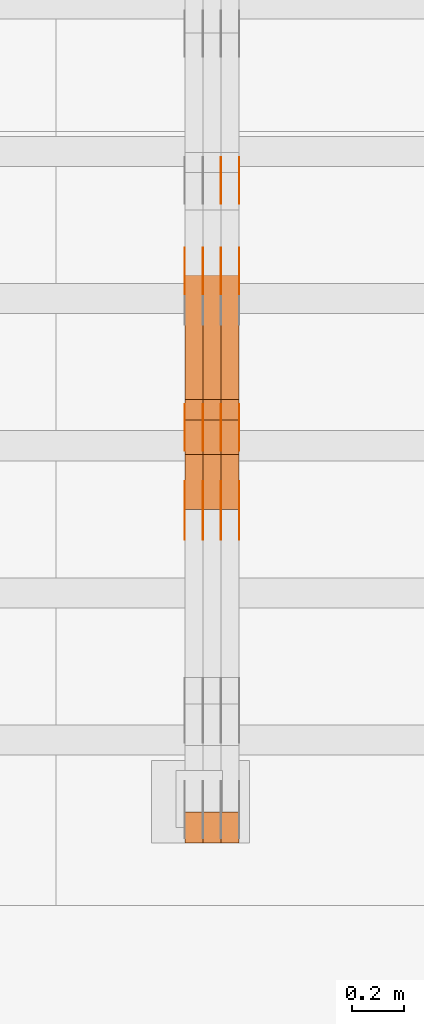
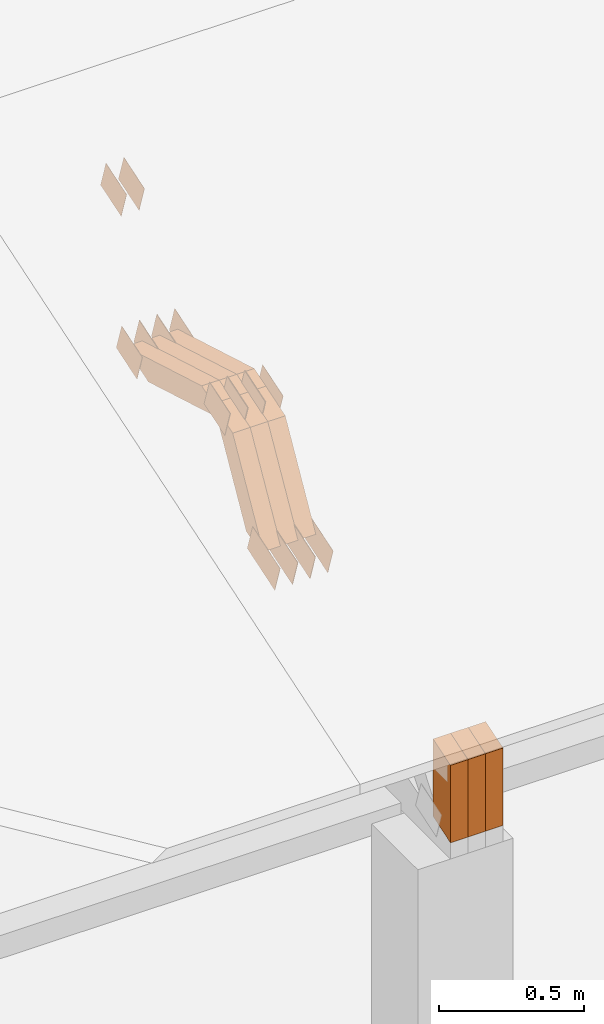
# One storey, part 129 of 385: 29 proxies.
"""IFC2X3 building model written with IfcOpenShell, lengths in millimetres."""

from ifc_helpers import new_model, entity, si_unit, converted_unit, derived_unit, direction, frame, origin, place, context, subcontext, project, spatial, polyline, outline, extrude, source, transform, mapped, material, type_object, type_shapes, element, save


model = new_model("IFC2X3")

# Units and contexts
model_context = context("Model", 3, precision=0.01, world=origin(), true_north=direction((6.12303176911189e-17, 1.0)))
body_context = subcontext(model_context, "Body", "Model", "MODEL_VIEW")
ifc_project = project(units=[si_unit("LENGTHUNIT", "METRE", prefix="MILLI"), si_unit("AREAUNIT", "SQUARE_METRE"), si_unit("VOLUMEUNIT", "CUBIC_METRE"), converted_unit("PLANEANGLEUNIT", "DEGREE", entity("IfcRatioMeasure", 0.0174532925199433), si_unit("PLANEANGLEUNIT", "RADIAN"), dimensions=[0, 0, 0, 0, 0, 0, 0]), si_unit("MASSUNIT", "GRAM", prefix="KILO"), derived_unit("MASSDENSITYUNIT", [(si_unit("MASSUNIT", "GRAM", prefix="KILO"), 1), (si_unit("LENGTHUNIT", "METRE"), -3)]), si_unit("TIMEUNIT", "SECOND"), si_unit("FREQUENCYUNIT", "HERTZ"), si_unit("THERMODYNAMICTEMPERATUREUNIT", "DEGREE_CELSIUS"), derived_unit("THERMALTRANSMITTANCEUNIT", [(si_unit("MASSUNIT", "GRAM", prefix="KILO"), 1), (si_unit("THERMODYNAMICTEMPERATUREUNIT", "KELVIN"), -1), (si_unit("TIMEUNIT", "SECOND"), -3)]), derived_unit("VOLUMETRICFLOWRATEUNIT", [(si_unit("LENGTHUNIT", "METRE"), 3), (si_unit("TIMEUNIT", "SECOND"), -1)]), si_unit("ELECTRICCURRENTUNIT", "AMPERE"), si_unit("ELECTRICVOLTAGEUNIT", "VOLT"), si_unit("POWERUNIT", "WATT"), si_unit("FORCEUNIT", "NEWTON", prefix="KILO"), si_unit("ILLUMINANCEUNIT", "LUX"), si_unit("LUMINOUSFLUXUNIT", "LUMEN"), si_unit("LUMINOUSINTENSITYUNIT", "CANDELA"), derived_unit("USERDEFINED", [(si_unit("MASSUNIT", "GRAM", prefix="KILO"), -1), (si_unit("LENGTHUNIT", "METRE"), -2), (si_unit("TIMEUNIT", "SECOND"), 3), (si_unit("LUMINOUSFLUXUNIT", "LUMEN"), 1)]), derived_unit("LINEARVELOCITYUNIT", [(si_unit("LENGTHUNIT", "METRE"), 1), (si_unit("TIMEUNIT", "SECOND"), -1)]), si_unit("PRESSUREUNIT", "PASCAL"), derived_unit("USERDEFINED", [(si_unit("LENGTHUNIT", "METRE"), -2), (si_unit("MASSUNIT", "GRAM", prefix="KILO"), 1), (si_unit("TIMEUNIT", "SECOND"), -2)])], contexts=[model_context])

# Site, building, storey
site_placement = place(None, origin())
site = spatial("IfcSite", under=ifc_project, at=site_placement, CompositionType="ELEMENT")
building_placement = place(site_placement, origin())
building = spatial("IfcBuilding", under=site, at=building_placement, CompositionType="ELEMENT")
storey_placement = place(building_placement, origin())
storey = spatial("IfcBuildingStorey", under=building, at=storey_placement, Name="Default", CompositionType="ELEMENT", Elevation=0.0)

# Proxies
ifc_material_1 = material(Name="IfcSurfaceStyle #374118")
building_element_proxy_type_1 = type_object("IfcBuildingElementProxyType", PredefinedType="NOTDEFINED", material=ifc_material_1)
shared_shape_1 = source(origin(), body_context, "Body", "SweptSolid", [
    extrude(outline(polyline([(-99.9998204243802, -60.000067376167), (99.9998338462265, -60.000067376167), (99.9998204243802, 60.000067376167), (-99.9998338462265, 60.000067376167), (-99.9998204243802, -60.000067376167)])), frame((100.000602015329, 60.0001864986889, 0.0), z_axis=(0.0, 0.0, 1.0), x_axis=(-1.0, 0.0, 0.0)), (0.0, 0.0, 1.0), 1.3),
])
type_shapes(building_element_proxy_type_1, [shared_shape_1])
proxy_1_placement = place(building_placement, frame((30386.3, 4114.85465165112, 513.097031388771), z_axis=(-1.0, 0.0, 0.0), x_axis=(0.0, 0.951056516295124, 0.309016994375039)))
element("IfcBuildingElementProxy", 1, at=proxy_1_placement, inside=storey, type_object=building_element_proxy_type_1, material=ifc_material_1, context=body_context, shape_type="MappedRepresentation", body=[
    mapped(shared_shape_1, transform((0.0, 0.0, 0.0), scale=1.0)),
])
ifc_material_2 = material(Name="IfcSurfaceStyle #374061")
building_element_proxy_type_2 = type_object("IfcBuildingElementProxyType", PredefinedType="NOTDEFINED", material=ifc_material_2)
shared_shape_2 = source(origin(), body_context, "Body", "SweptSolid", [
    extrude(outline(polyline([(-99.9998204243802, -60.000067376167), (99.9998338462265, -60.000067376167), (99.9998204243802, 60.000067376167), (-99.9998338462265, 60.000067376167), (-99.9998204243802, -60.000067376167)])), frame((100.000602015329, 60.0001864986889, 0.0), z_axis=(0.0, 0.0, 1.0), x_axis=(-1.0, 0.0, 0.0)), (0.0, 0.0, 1.0), 1.3),
])
type_shapes(building_element_proxy_type_2, [shared_shape_2])
proxy_2_placement = place(building_placement, frame((30315.0, 4114.85465165112, 513.097031388771), z_axis=(-1.0, 0.0, 0.0), x_axis=(0.0, 0.951056516295124, 0.309016994375039)))
element("IfcBuildingElementProxy", 2, at=proxy_2_placement, inside=storey, type_object=building_element_proxy_type_2, material=ifc_material_2, context=body_context, shape_type="MappedRepresentation", body=[
    mapped(shared_shape_2, transform((0.0, 0.0, 0.0), scale=1.0)),
])
ifc_material_3 = material(Name="IfcSurfaceStyle #374004")
building_element_proxy_type_3 = type_object("IfcBuildingElementProxyType", PredefinedType="NOTDEFINED", material=ifc_material_3)
shared_shape_3 = source(origin(), body_context, "Body", "SweptSolid", [
    extrude(outline(polyline([(-99.9998204243802, -60.000067376167), (99.9998338462265, -60.000067376167), (99.9998204243802, 60.000067376167), (-99.9998338462265, 60.000067376167), (-99.9998204243802, -60.000067376167)])), frame((100.000602015329, 60.0001864986889, 0.0), z_axis=(0.0, 0.0, 1.0), x_axis=(-1.0, 0.0, 0.0)), (0.0, 0.0, 1.0), 1.3),
])
type_shapes(building_element_proxy_type_3, [shared_shape_3])
proxy_3_placement = place(building_placement, frame((30316.3, 4114.85465165112, 513.097031388771), z_axis=(-1.0, 0.0, 0.0), x_axis=(0.0, 0.951056516295124, 0.309016994375039)))
element("IfcBuildingElementProxy", 3, at=proxy_3_placement, inside=storey, type_object=building_element_proxy_type_3, material=ifc_material_3, context=body_context, shape_type="MappedRepresentation", body=[
    mapped(shared_shape_3, transform((0.0, 0.0, 0.0), scale=1.0)),
])
ifc_material_4 = material(Name="IfcSurfaceStyle #373947")
building_element_proxy_type_4 = type_object("IfcBuildingElementProxyType", PredefinedType="NOTDEFINED", material=ifc_material_4)
shared_shape_4 = source(origin(), body_context, "Body", "SweptSolid", [
    extrude(outline(polyline([(-99.9998204243802, -60.000067376167), (99.9998338462265, -60.000067376167), (99.9998204243802, 60.000067376167), (-99.9998338462265, 60.000067376167), (-99.9998204243802, -60.000067376167)])), frame((100.000602015329, 60.0001864986889, 0.0), z_axis=(0.0, 0.0, 1.0), x_axis=(-1.0, 0.0, 0.0)), (0.0, 0.0, 1.0), 1.29999999999998),
])
type_shapes(building_element_proxy_type_4, [shared_shape_4])
proxy_4_placement = place(building_placement, frame((30245.0, 4114.85465165112, 513.097031388771), z_axis=(-1.0, 0.0, 0.0), x_axis=(0.0, 0.951056516295124, 0.309016994375039)))
element("IfcBuildingElementProxy", 4, at=proxy_4_placement, inside=storey, type_object=building_element_proxy_type_4, material=ifc_material_4, context=body_context, shape_type="MappedRepresentation", body=[
    mapped(shared_shape_4, transform((0.0, 0.0, 0.0), scale=1.0)),
])
ifc_material_5 = material(Name="IfcSurfaceStyle #373890")
building_element_proxy_type_5 = type_object("IfcBuildingElementProxyType", PredefinedType="NOTDEFINED", material=ifc_material_5)
shared_shape_5 = source(origin(), body_context, "Body", "SweptSolid", [
    extrude(outline(polyline([(-99.9998204243802, -60.000067376167), (99.9998338462265, -60.000067376167), (99.9998204243802, 60.000067376167), (-99.9998338462265, 60.000067376167), (-99.9998204243802, -60.000067376167)])), frame((100.000602015329, 60.0001864986889, 0.0), z_axis=(0.0, 0.0, 1.0), x_axis=(-1.0, 0.0, 0.0)), (0.0, 0.0, 1.0), 1.29999999999998),
])
type_shapes(building_element_proxy_type_5, [shared_shape_5])
proxy_5_placement = place(building_placement, frame((30246.3, 4114.85465165112, 513.097031388771), z_axis=(-1.0, 0.0, 0.0), x_axis=(0.0, 0.951056516295124, 0.309016994375039)))
element("IfcBuildingElementProxy", 5, at=proxy_5_placement, inside=storey, type_object=building_element_proxy_type_5, material=ifc_material_5, context=body_context, shape_type="MappedRepresentation", body=[
    mapped(shared_shape_5, transform((0.0, 0.0, 0.0), scale=1.0)),
])
ifc_material_6 = material(Name="IfcSurfaceStyle #373833")
building_element_proxy_type_6 = type_object("IfcBuildingElementProxyType", PredefinedType="NOTDEFINED", material=ifc_material_6)
shared_shape_6 = source(origin(), body_context, "Body", "SweptSolid", [
    extrude(outline(polyline([(-99.9998204243802, -60.000067376167), (99.9998338462265, -60.000067376167), (99.9998204243802, 60.000067376167), (-99.9998338462265, 60.000067376167), (-99.9998204243802, -60.000067376167)])), frame((100.000602015329, 60.0001864986889, 0.0), z_axis=(0.0, 0.0, 1.0), x_axis=(-1.0, 0.0, 0.0)), (0.0, 0.0, 1.0), 1.29999999999999),
])
type_shapes(building_element_proxy_type_6, [shared_shape_6])
proxy_6_placement = place(building_placement, frame((30175.0, 4114.85465165112, 513.097031388771), z_axis=(-1.0, 0.0, 0.0), x_axis=(0.0, 0.951056516295124, 0.309016994375039)))
element("IfcBuildingElementProxy", 6, at=proxy_6_placement, inside=storey, type_object=building_element_proxy_type_6, material=ifc_material_6, context=body_context, shape_type="MappedRepresentation", body=[
    mapped(shared_shape_6, transform((0.0, 0.0, 0.0), scale=1.0)),
])
ifc_material_7 = material(Name="IfcSurfaceStyle #373776")
building_element_proxy_type_7 = type_object("IfcBuildingElementProxyType", PredefinedType="NOTDEFINED", material=ifc_material_7)
shared_shape_7 = source(origin(), body_context, "Body", "SweptSolid", [
    extrude(outline(polyline([(-74.9998707133927, -60.0000596852269), (74.9998841352353, -60.0000596852269), (74.999861282944, 60.0000596852269), (-74.9998747047866, 60.0000596852269), (-74.9998707133927, -60.0000596852269)])), frame((74.9998841352353, 60.0000596852269, 0.0), z_axis=(0.0, 0.0, 1.0), x_axis=(-1.0, 0.0, 0.0)), (0.0, 0.0, 1.0), 1.3),
])
type_shapes(building_element_proxy_type_7, [shared_shape_7])
proxy_7_placement = place(building_placement, frame((30386.3, 5067.4882362875, 826.131473120182), z_axis=(-1.0, 0.0, 0.0), x_axis=(0.0, 0.951056516295124, 0.309016994375039)))
element("IfcBuildingElementProxy", 7, at=proxy_7_placement, inside=storey, type_object=building_element_proxy_type_7, material=ifc_material_7, context=body_context, shape_type="MappedRepresentation", body=[
    mapped(shared_shape_7, transform((0.0, 0.0, 0.0), scale=1.0)),
])
ifc_material_8 = material(Name="IfcSurfaceStyle #373719")
building_element_proxy_type_8 = type_object("IfcBuildingElementProxyType", PredefinedType="NOTDEFINED", material=ifc_material_8)
shared_shape_8 = source(origin(), body_context, "Body", "SweptSolid", [
    extrude(outline(polyline([(-74.9998707133927, -60.0000596852269), (74.9998841352353, -60.0000596852269), (74.999861282944, 60.0000596852269), (-74.9998747047866, 60.0000596852269), (-74.9998707133927, -60.0000596852269)])), frame((74.9998841352353, 60.0000596852269, 0.0), z_axis=(0.0, 0.0, 1.0), x_axis=(-1.0, 0.0, 0.0)), (0.0, 0.0, 1.0), 1.3),
])
type_shapes(building_element_proxy_type_8, [shared_shape_8])
proxy_8_placement = place(building_placement, frame((30315.0, 5067.4882362875, 826.131473120182), z_axis=(-1.0, 0.0, 0.0), x_axis=(0.0, 0.951056516295124, 0.309016994375039)))
element("IfcBuildingElementProxy", 8, at=proxy_8_placement, inside=storey, type_object=building_element_proxy_type_8, material=ifc_material_8, context=body_context, shape_type="MappedRepresentation", body=[
    mapped(shared_shape_8, transform((0.0, 0.0, 0.0), scale=1.0)),
])
ifc_material_9 = material(Name="IfcSurfaceStyle #373662")
building_element_proxy_type_9 = type_object("IfcBuildingElementProxyType", PredefinedType="NOTDEFINED", material=ifc_material_9)
shared_shape_9 = source(origin(), body_context, "Body", "SweptSolid", [
    extrude(outline(polyline([(-74.9998707133927, -60.0000596852269), (74.9998841352353, -60.0000596852269), (74.999861282944, 60.0000596852269), (-74.9998747047866, 60.0000596852269), (-74.9998707133927, -60.0000596852269)])), frame((74.9998841352353, 60.0000596852269, 0.0), z_axis=(0.0, 0.0, 1.0), x_axis=(-1.0, 0.0, 0.0)), (0.0, 0.0, 1.0), 1.3),
])
type_shapes(building_element_proxy_type_9, [shared_shape_9])
proxy_9_placement = place(building_placement, frame((30316.3, 5067.4882362875, 826.131473120182), z_axis=(-1.0, 0.0, 0.0), x_axis=(0.0, 0.951056516295124, 0.309016994375039)))
element("IfcBuildingElementProxy", 9, at=proxy_9_placement, inside=storey, type_object=building_element_proxy_type_9, material=ifc_material_9, context=body_context, shape_type="MappedRepresentation", body=[
    mapped(shared_shape_9, transform((0.0, 0.0, 0.0), scale=1.0)),
])
ifc_material_10 = material(Name="IfcSurfaceStyle #373605")
building_element_proxy_type_10 = type_object("IfcBuildingElementProxyType", PredefinedType="NOTDEFINED", material=ifc_material_10)
shared_shape_10 = source(origin(), body_context, "Body", "SweptSolid", [
    extrude(outline(polyline([(-74.9998707133927, -60.0000596852269), (74.9998841352353, -60.0000596852269), (74.999861282944, 60.0000596852269), (-74.9998747047866, 60.0000596852269), (-74.9998707133927, -60.0000596852269)])), frame((74.9998841352353, 60.0000596852269, 0.0), z_axis=(0.0, 0.0, 1.0), x_axis=(-1.0, 0.0, 0.0)), (0.0, 0.0, 1.0), 1.29999999999999),
])
type_shapes(building_element_proxy_type_10, [shared_shape_10])
proxy_10_placement = place(building_placement, frame((30245.0, 5067.4882362875, 826.131473120182), z_axis=(-1.0, 0.0, 0.0), x_axis=(0.0, 0.951056516295124, 0.309016994375039)))
element("IfcBuildingElementProxy", 10, at=proxy_10_placement, inside=storey, type_object=building_element_proxy_type_10, material=ifc_material_10, context=body_context, shape_type="MappedRepresentation", body=[
    mapped(shared_shape_10, transform((0.0, 0.0, 0.0), scale=1.0)),
])
ifc_material_11 = material(Name="IfcSurfaceStyle #373548")
building_element_proxy_type_11 = type_object("IfcBuildingElementProxyType", PredefinedType="NOTDEFINED", material=ifc_material_11)
shared_shape_11 = source(origin(), body_context, "Body", "SweptSolid", [
    extrude(outline(polyline([(-74.9998707133927, -60.0000596852269), (74.9998841352353, -60.0000596852269), (74.999861282944, 60.0000596852269), (-74.9998747047866, 60.0000596852269), (-74.9998707133927, -60.0000596852269)])), frame((74.9998841352353, 60.0000596852269, 0.0), z_axis=(0.0, 0.0, 1.0), x_axis=(-1.0, 0.0, 0.0)), (0.0, 0.0, 1.0), 1.29999999999999),
])
type_shapes(building_element_proxy_type_11, [shared_shape_11])
proxy_11_placement = place(building_placement, frame((30246.3, 5067.4882362875, 826.131473120182), z_axis=(-1.0, 0.0, 0.0), x_axis=(0.0, 0.951056516295124, 0.309016994375039)))
element("IfcBuildingElementProxy", 11, at=proxy_11_placement, inside=storey, type_object=building_element_proxy_type_11, material=ifc_material_11, context=body_context, shape_type="MappedRepresentation", body=[
    mapped(shared_shape_11, transform((0.0, 0.0, 0.0), scale=1.0)),
])
ifc_material_12 = material(Name="IfcSurfaceStyle #373491")
building_element_proxy_type_12 = type_object("IfcBuildingElementProxyType", PredefinedType="NOTDEFINED", material=ifc_material_12)
shared_shape_12 = source(origin(), body_context, "Body", "SweptSolid", [
    extrude(outline(polyline([(-74.9998707133927, -60.0000596852269), (74.9998841352353, -60.0000596852269), (74.999861282944, 60.0000596852269), (-74.9998747047866, 60.0000596852269), (-74.9998707133927, -60.0000596852269)])), frame((74.9998841352353, 60.0000596852269, 0.0), z_axis=(0.0, 0.0, 1.0), x_axis=(-1.0, 0.0, 0.0)), (0.0, 0.0, 1.0), 1.29999999999999),
])
type_shapes(building_element_proxy_type_12, [shared_shape_12])
proxy_12_placement = place(building_placement, frame((30175.0, 5067.4882362875, 826.131473120182), z_axis=(-1.0, 0.0, 0.0), x_axis=(0.0, 0.951056516295124, 0.309016994375039)))
element("IfcBuildingElementProxy", 12, at=proxy_12_placement, inside=storey, type_object=building_element_proxy_type_12, material=ifc_material_12, context=body_context, shape_type="MappedRepresentation", body=[
    mapped(shared_shape_12, transform((0.0, 0.0, 0.0), scale=1.0)),
])
ifc_material_13 = material(Name="IfcSurfaceStyle #367962")
building_element_proxy_type_13 = type_object("IfcBuildingElementProxyType", PredefinedType="NOTDEFINED", material=ifc_material_13)
shared_shape_13 = source(origin(), body_context, "Body", "SweptSolid", [
    extrude(outline(polyline([(-74.9998565677224, -60.0000596852342), (74.9998794200083, -60.0000596852342), (74.9998565677242, 60.0000596852342), (-74.9998794200101, 60.0000596852342), (-74.9998565677224, -60.0000596852342)])), frame((74.9998794200083, 60.0000596852342, 0.0), z_axis=(0.0, 0.0, 1.0), x_axis=(-1.0, 0.0, 0.0)), (0.0, 0.0, 1.0), 1.3),
])
type_shapes(building_element_proxy_type_13, [shared_shape_13])
proxy_13_placement = place(building_placement, frame((30386.3, 5418.6991737875, 1250.81341892098), z_axis=(-1.0, 0.0, 0.0), x_axis=(0.0, 0.951056516295154, 0.309016994374948)))
element("IfcBuildingElementProxy", 13, at=proxy_13_placement, inside=storey, type_object=building_element_proxy_type_13, material=ifc_material_13, context=body_context, shape_type="MappedRepresentation", body=[
    mapped(shared_shape_13, transform((0.0, 0.0, 0.0), scale=1.0)),
])
ifc_material_14 = material(Name="IfcSurfaceStyle #367905")
building_element_proxy_type_14 = type_object("IfcBuildingElementProxyType", PredefinedType="NOTDEFINED", material=ifc_material_14)
shared_shape_14 = source(origin(), body_context, "Body", "SweptSolid", [
    extrude(outline(polyline([(-74.9998565677224, -60.0000596852342), (74.9998794200083, -60.0000596852342), (74.9998565677242, 60.0000596852342), (-74.9998794200101, 60.0000596852342), (-74.9998565677224, -60.0000596852342)])), frame((74.9998794200083, 60.0000596852342, 0.0), z_axis=(0.0, 0.0, 1.0), x_axis=(-1.0, 0.0, 0.0)), (0.0, 0.0, 1.0), 1.3),
])
type_shapes(building_element_proxy_type_14, [shared_shape_14])
proxy_14_placement = place(building_placement, frame((30315.0, 5418.6991737875, 1250.81341892098), z_axis=(-1.0, 0.0, 0.0), x_axis=(0.0, 0.951056516295154, 0.309016994374948)))
element("IfcBuildingElementProxy", 14, at=proxy_14_placement, inside=storey, type_object=building_element_proxy_type_14, material=ifc_material_14, context=body_context, shape_type="MappedRepresentation", body=[
    mapped(shared_shape_14, transform((0.0, 0.0, 0.0), scale=1.0)),
])
ifc_material_15 = material(Name="IfcSurfaceStyle #366936")
building_element_proxy_type_15 = type_object("IfcBuildingElementProxyType", PredefinedType="NOTDEFINED", material=ifc_material_15)
shared_shape_15 = source(origin(), body_context, "Body", "SweptSolid", [
    extrude(outline(polyline([(-74.999865998172, -60.0000306612919), (74.999869989555, -60.0000306612919), (74.999865998172, 60.0000306612919), (-74.999869989555, 60.0000306612919), (-74.999865998172, -60.0000306612919)])), frame((75.0006726017528, 60.0001996460842, 0.0), z_axis=(0.0, 0.0, 1.0), x_axis=(-1.0, 0.0, 0.0)), (0.0, 0.0, 1.0), 1.3),
])
type_shapes(building_element_proxy_type_15, [shared_shape_15])
proxy_15_placement = place(building_placement, frame((30386.3, 4460.38978242656, 957.314497110567), z_axis=(-1.0, 0.0, 0.0), x_axis=(0.0, 0.951056516295154, 0.309016994374948)))
element("IfcBuildingElementProxy", 15, at=proxy_15_placement, inside=storey, type_object=building_element_proxy_type_15, material=ifc_material_15, context=body_context, shape_type="MappedRepresentation", body=[
    mapped(shared_shape_15, transform((0.0, 0.0, 0.0), scale=1.0)),
])
ifc_material_16 = material(Name="IfcSurfaceStyle #366879")
building_element_proxy_type_16 = type_object("IfcBuildingElementProxyType", PredefinedType="NOTDEFINED", material=ifc_material_16)
shared_shape_16 = source(origin(), body_context, "Body", "SweptSolid", [
    extrude(outline(polyline([(-74.999865998172, -60.0000306612919), (74.999869989555, -60.0000306612919), (74.999865998172, 60.0000306612919), (-74.999869989555, 60.0000306612919), (-74.999865998172, -60.0000306612919)])), frame((75.0006726017528, 60.0001996460842, 0.0), z_axis=(0.0, 0.0, 1.0), x_axis=(-1.0, 0.0, 0.0)), (0.0, 0.0, 1.0), 1.3),
])
type_shapes(building_element_proxy_type_16, [shared_shape_16])
proxy_16_placement = place(building_placement, frame((30315.0, 4460.38978242656, 957.314497110567), z_axis=(-1.0, 0.0, 0.0), x_axis=(0.0, 0.951056516295154, 0.309016994374948)))
element("IfcBuildingElementProxy", 16, at=proxy_16_placement, inside=storey, type_object=building_element_proxy_type_16, material=ifc_material_16, context=body_context, shape_type="MappedRepresentation", body=[
    mapped(shared_shape_16, transform((0.0, 0.0, 0.0), scale=1.0)),
])
ifc_material_17 = material(Name="IfcSurfaceStyle #366822")
building_element_proxy_type_17 = type_object("IfcBuildingElementProxyType", PredefinedType="NOTDEFINED", material=ifc_material_17)
shared_shape_17 = source(origin(), body_context, "Body", "SweptSolid", [
    extrude(outline(polyline([(-74.999865998172, -60.0000306612919), (74.999869989555, -60.0000306612919), (74.999865998172, 60.0000306612919), (-74.999869989555, 60.0000306612919), (-74.999865998172, -60.0000306612919)])), frame((75.0006726017528, 60.0001996460842, 0.0), z_axis=(0.0, 0.0, 1.0), x_axis=(-1.0, 0.0, 0.0)), (0.0, 0.0, 1.0), 1.3),
])
type_shapes(building_element_proxy_type_17, [shared_shape_17])
proxy_17_placement = place(building_placement, frame((30316.3, 4460.38978242656, 957.314497110567), z_axis=(-1.0, 0.0, 0.0), x_axis=(0.0, 0.951056516295154, 0.309016994374948)))
element("IfcBuildingElementProxy", 17, at=proxy_17_placement, inside=storey, type_object=building_element_proxy_type_17, material=ifc_material_17, context=body_context, shape_type="MappedRepresentation", body=[
    mapped(shared_shape_17, transform((0.0, 0.0, 0.0), scale=1.0)),
])
ifc_material_18 = material(Name="IfcSurfaceStyle #366765")
building_element_proxy_type_18 = type_object("IfcBuildingElementProxyType", PredefinedType="NOTDEFINED", material=ifc_material_18)
shared_shape_18 = source(origin(), body_context, "Body", "SweptSolid", [
    extrude(outline(polyline([(-74.999865998172, -60.0000306612919), (74.999869989555, -60.0000306612919), (74.999865998172, 60.0000306612919), (-74.999869989555, 60.0000306612919), (-74.999865998172, -60.0000306612919)])), frame((75.0006726017528, 60.0001996460842, 0.0), z_axis=(0.0, 0.0, 1.0), x_axis=(-1.0, 0.0, 0.0)), (0.0, 0.0, 1.0), 1.29999999999999),
])
type_shapes(building_element_proxy_type_18, [shared_shape_18])
proxy_18_placement = place(building_placement, frame((30245.0, 4460.38978242656, 957.314497110567), z_axis=(-1.0, 0.0, 0.0), x_axis=(0.0, 0.951056516295154, 0.309016994374948)))
element("IfcBuildingElementProxy", 18, at=proxy_18_placement, inside=storey, type_object=building_element_proxy_type_18, material=ifc_material_18, context=body_context, shape_type="MappedRepresentation", body=[
    mapped(shared_shape_18, transform((0.0, 0.0, 0.0), scale=1.0)),
])
ifc_material_19 = material(Name="IfcSurfaceStyle #366708")
building_element_proxy_type_19 = type_object("IfcBuildingElementProxyType", PredefinedType="NOTDEFINED", material=ifc_material_19)
shared_shape_19 = source(origin(), body_context, "Body", "SweptSolid", [
    extrude(outline(polyline([(-74.999865998172, -60.0000306612919), (74.999869989555, -60.0000306612919), (74.999865998172, 60.0000306612919), (-74.999869989555, 60.0000306612919), (-74.999865998172, -60.0000306612919)])), frame((75.0006726017528, 60.0001996460842, 0.0), z_axis=(0.0, 0.0, 1.0), x_axis=(-1.0, 0.0, 0.0)), (0.0, 0.0, 1.0), 1.29999999999999),
])
type_shapes(building_element_proxy_type_19, [shared_shape_19])
proxy_19_placement = place(building_placement, frame((30246.3, 4460.38978242656, 957.314497110567), z_axis=(-1.0, 0.0, 0.0), x_axis=(0.0, 0.951056516295154, 0.309016994374948)))
element("IfcBuildingElementProxy", 19, at=proxy_19_placement, inside=storey, type_object=building_element_proxy_type_19, material=ifc_material_19, context=body_context, shape_type="MappedRepresentation", body=[
    mapped(shared_shape_19, transform((0.0, 0.0, 0.0), scale=1.0)),
])
ifc_material_20 = material(Name="IfcSurfaceStyle #366651")
building_element_proxy_type_20 = type_object("IfcBuildingElementProxyType", PredefinedType="NOTDEFINED", material=ifc_material_20)
shared_shape_20 = source(origin(), body_context, "Body", "SweptSolid", [
    extrude(outline(polyline([(-74.999865998172, -60.0000306612919), (74.999869989555, -60.0000306612919), (74.999865998172, 60.0000306612919), (-74.999869989555, 60.0000306612919), (-74.999865998172, -60.0000306612919)])), frame((75.0006726017528, 60.0001996460842, 0.0), z_axis=(0.0, 0.0, 1.0), x_axis=(-1.0, 0.0, 0.0)), (0.0, 0.0, 1.0), 1.29999999999999),
])
type_shapes(building_element_proxy_type_20, [shared_shape_20])
proxy_20_placement = place(building_placement, frame((30175.0, 4460.38978242656, 957.314497110567), z_axis=(-1.0, 0.0, 0.0), x_axis=(0.0, 0.951056516295154, 0.309016994374948)))
element("IfcBuildingElementProxy", 20, at=proxy_20_placement, inside=storey, type_object=building_element_proxy_type_20, material=ifc_material_20, context=body_context, shape_type="MappedRepresentation", body=[
    mapped(shared_shape_20, transform((0.0, 0.0, 0.0), scale=1.0)),
])
ifc_material_21 = material(Name="IfcSurfaceStyle #354408")
building_element_proxy_type_21 = type_object("IfcBuildingElementProxyType", Name="T1-W12 354406", PredefinedType="NOTDEFINED", material=ifc_material_21)
shared_shape_21 = source(origin(), body_context, "Body", "SweptSolid", [
    extrude(outline(polyline([(-249.405625983165, -47.5001691155616), (243.345753908996, -47.5001691155616), (232.115534842595, 2.39993474701938e-05), (162.527010966644, 47.5001571158879), (-388.58267373507, 47.5001571158879), (-249.405625983165, -47.5001691155616)])), frame((243.345867653852, 47.5001571158879, 0.0), z_axis=(0.0, 0.0, 1.0), x_axis=(-1.0, 0.0, 0.0)), (0.0, 0.0, 1.0), 70.0),
])
type_shapes(building_element_proxy_type_21, [shared_shape_21])
proxy_21_placement = place(building_placement, frame((30385.0, 4581.32698473631, 976.172276753357), z_axis=(-1.0, 0.0, 0.0), x_axis=(0.0, 0.959722067881787, -0.280951156645966)))
element("IfcBuildingElementProxy", 21, at=proxy_21_placement, inside=storey, type_object=building_element_proxy_type_21, material=ifc_material_21, Name="T1-W12", context=body_context, shape_type="MappedRepresentation", body=[
    mapped(shared_shape_21, transform((0.0, 0.0, 0.0), scale=1.0)),
])
ifc_material_22 = material(Name="IfcSurfaceStyle #354342")
building_element_proxy_type_22 = type_object("IfcBuildingElementProxyType", Name="T1-W12 354340", PredefinedType="NOTDEFINED", material=ifc_material_22)
shared_shape_22 = source(origin(), body_context, "Body", "SweptSolid", [
    extrude(outline(polyline([(-249.405625983165, -47.5001691155616), (243.345753908996, -47.5001691155616), (232.115534842595, 2.39993474701938e-05), (162.527010966644, 47.5001571158879), (-388.58267373507, 47.5001571158879), (-249.405625983165, -47.5001691155616)])), frame((243.345867653852, 47.5001571158879, 0.0), z_axis=(0.0, 0.0, 1.0), x_axis=(-1.0, 0.0, 0.0)), (0.0, 0.0, 1.0), 70.0),
])
type_shapes(building_element_proxy_type_22, [shared_shape_22])
proxy_22_placement = place(building_placement, frame((30315.0, 4581.32698473631, 976.172276753357), z_axis=(-1.0, 0.0, 0.0), x_axis=(0.0, 0.959722067881787, -0.280951156645966)))
element("IfcBuildingElementProxy", 22, at=proxy_22_placement, inside=storey, type_object=building_element_proxy_type_22, material=ifc_material_22, Name="T1-W12", context=body_context, shape_type="MappedRepresentation", body=[
    mapped(shared_shape_22, transform((0.0, 0.0, 0.0), scale=1.0)),
])
ifc_material_23 = material(Name="IfcSurfaceStyle #354276")
building_element_proxy_type_23 = type_object("IfcBuildingElementProxyType", Name="T1-W12 354274", PredefinedType="NOTDEFINED", material=ifc_material_23)
shared_shape_23 = source(origin(), body_context, "Body", "SweptSolid", [
    extrude(outline(polyline([(-249.405625983165, -47.5001691155616), (243.345753908996, -47.5001691155616), (232.115534842595, 2.39993474701938e-05), (162.527010966644, 47.5001571158879), (-388.58267373507, 47.5001571158879), (-249.405625983165, -47.5001691155616)])), frame((243.345867653852, 47.5001571158879, 0.0), z_axis=(0.0, 0.0, 1.0), x_axis=(-1.0, 0.0, 0.0)), (0.0, 0.0, 1.0), 70.0),
])
type_shapes(building_element_proxy_type_23, [shared_shape_23])
proxy_23_placement = place(building_placement, frame((30245.0, 4581.32698473631, 976.172276753357), z_axis=(-1.0, 0.0, 0.0), x_axis=(0.0, 0.959722067881787, -0.280951156645966)))
element("IfcBuildingElementProxy", 23, at=proxy_23_placement, inside=storey, type_object=building_element_proxy_type_23, material=ifc_material_23, Name="T1-W12", context=body_context, shape_type="MappedRepresentation", body=[
    mapped(shared_shape_23, transform((0.0, 0.0, 0.0), scale=1.0)),
])
ifc_material_24 = material(Name="IfcSurfaceStyle #354012")
building_element_proxy_type_24 = type_object("IfcBuildingElementProxyType", Name="T1-W27 354010", PredefinedType="NOTDEFINED", material=ifc_material_24)
shared_shape_24 = source(origin(), body_context, "Body", "SweptSolid", [
    extrude(outline(polyline([(-321.979763159708, -47.49993999164), (138.960018341432, -47.49993999164), (191.013775341887, -0.000473170132329126), (209.87827169492, 47.5001765767061), (-217.872302218531, 47.5001765767062), (-321.979763159708, -47.49993999164)])), frame((209.87827169492, 47.5001765767061, 0.0), z_axis=(0.0, 0.0, 1.0), x_axis=(-1.0, 0.0, 0.0)), (0.0, 0.0, 1.0), 70.0),
])
type_shapes(building_element_proxy_type_24, [shared_shape_24])
proxy_24_placement = place(building_placement, frame((30385.0, 4233.3125, 512.021728515625), z_axis=(-1.0, 0.0, 0.0), x_axis=(0.0, 0.494231057369727, 0.869330582650352)))
element("IfcBuildingElementProxy", 24, at=proxy_24_placement, inside=storey, type_object=building_element_proxy_type_24, material=ifc_material_24, Name="T1-W27", context=body_context, shape_type="MappedRepresentation", body=[
    mapped(shared_shape_24, transform((0.0, 0.0, 0.0), scale=1.0)),
])
ifc_material_25 = material(Name="IfcSurfaceStyle #353946")
building_element_proxy_type_25 = type_object("IfcBuildingElementProxyType", Name="T1-W27 353944", PredefinedType="NOTDEFINED", material=ifc_material_25)
shared_shape_25 = source(origin(), body_context, "Body", "SweptSolid", [
    extrude(outline(polyline([(-321.979763159708, -47.49993999164), (138.960018341432, -47.49993999164), (191.013775341887, -0.000473170132329126), (209.87827169492, 47.5001765767061), (-217.872302218531, 47.5001765767062), (-321.979763159708, -47.49993999164)])), frame((209.87827169492, 47.5001765767061, 0.0), z_axis=(0.0, 0.0, 1.0), x_axis=(-1.0, 0.0, 0.0)), (0.0, 0.0, 1.0), 70.0),
])
type_shapes(building_element_proxy_type_25, [shared_shape_25])
proxy_25_placement = place(building_placement, frame((30315.0, 4233.3125, 512.021728515625), z_axis=(-1.0, 0.0, 0.0), x_axis=(0.0, 0.494231057369727, 0.869330582650352)))
element("IfcBuildingElementProxy", 25, at=proxy_25_placement, inside=storey, type_object=building_element_proxy_type_25, material=ifc_material_25, Name="T1-W27", context=body_context, shape_type="MappedRepresentation", body=[
    mapped(shared_shape_25, transform((0.0, 0.0, 0.0), scale=1.0)),
])
ifc_material_26 = material(Name="IfcSurfaceStyle #353880")
building_element_proxy_type_26 = type_object("IfcBuildingElementProxyType", Name="T1-W27 353878", PredefinedType="NOTDEFINED", material=ifc_material_26)
shared_shape_26 = source(origin(), body_context, "Body", "SweptSolid", [
    extrude(outline(polyline([(-321.979763159708, -47.49993999164), (138.960018341432, -47.49993999164), (191.013775341887, -0.000473170132329126), (209.87827169492, 47.5001765767061), (-217.872302218531, 47.5001765767062), (-321.979763159708, -47.49993999164)])), frame((209.87827169492, 47.5001765767061, 0.0), z_axis=(0.0, 0.0, 1.0), x_axis=(-1.0, 0.0, 0.0)), (0.0, 0.0, 1.0), 70.0),
])
type_shapes(building_element_proxy_type_26, [shared_shape_26])
proxy_26_placement = place(building_placement, frame((30245.0, 4233.3125, 512.021728515625), z_axis=(-1.0, 0.0, 0.0), x_axis=(0.0, 0.494231057369727, 0.869330582650352)))
element("IfcBuildingElementProxy", 26, at=proxy_26_placement, inside=storey, type_object=building_element_proxy_type_26, material=ifc_material_26, Name="T1-W27", context=body_context, shape_type="MappedRepresentation", body=[
    mapped(shared_shape_26, transform((0.0, 0.0, 0.0), scale=1.0)),
])
ifc_material_27 = material(Name="IfcSurfaceStyle #353022")
building_element_proxy_type_27 = type_object("IfcBuildingElementProxyType", Name="T1-E3 353020", PredefinedType="NOTDEFINED", material=ifc_material_27)
shared_shape_27 = source(origin(), body_context, "Body", "SweptSolid", [
    extrude(outline(polyline([(-182.839673995971, -60.0), (143.849313735962, -60.0), (182.839677810669, 60.0), (-143.84931755066, 60.0), (-182.839673995971, -60.0)])), frame((182.839677810669, 60.0, 0.0), z_axis=(0.0, 0.0, 1.0), x_axis=(-1.0, 0.0, 0.0)), (0.0, 0.0, 1.0), 70.0),
])
type_shapes(building_element_proxy_type_27, [shared_shape_27])
proxy_27_placement = place(building_placement, frame((30385.0, 2940.0, 68.27587890625), z_axis=(-1.0, 0.0, 0.0), x_axis=(0.0, 0.0, 1.0)))
element("IfcBuildingElementProxy", 27, at=proxy_27_placement, inside=storey, type_object=building_element_proxy_type_27, material=ifc_material_27, Name="T1-E3", context=body_context, shape_type="MappedRepresentation", body=[
    mapped(shared_shape_27, transform((0.0, 0.0, 0.0), scale=1.0)),
])
ifc_material_28 = material(Name="IfcSurfaceStyle #352965")
building_element_proxy_type_28 = type_object("IfcBuildingElementProxyType", Name="T1-E3 352963", PredefinedType="NOTDEFINED", material=ifc_material_28)
shared_shape_28 = source(origin(), body_context, "Body", "SweptSolid", [
    extrude(outline(polyline([(-182.839673995971, -60.0), (143.849313735962, -60.0), (182.839677810669, 60.0), (-143.84931755066, 60.0), (-182.839673995971, -60.0)])), frame((182.839677810669, 60.0, 0.0), z_axis=(0.0, 0.0, 1.0), x_axis=(-1.0, 0.0, 0.0)), (0.0, 0.0, 1.0), 70.0),
])
type_shapes(building_element_proxy_type_28, [shared_shape_28])
proxy_28_placement = place(building_placement, frame((30315.0, 2940.0, 68.27587890625), z_axis=(-1.0, 0.0, 0.0), x_axis=(0.0, 0.0, 1.0)))
element("IfcBuildingElementProxy", 28, at=proxy_28_placement, inside=storey, type_object=building_element_proxy_type_28, material=ifc_material_28, Name="T1-E3", context=body_context, shape_type="MappedRepresentation", body=[
    mapped(shared_shape_28, transform((0.0, 0.0, 0.0), scale=1.0)),
])
ifc_material_29 = material(Name="IfcSurfaceStyle #352908")
building_element_proxy_type_29 = type_object("IfcBuildingElementProxyType", Name="T1-E3 352906", PredefinedType="NOTDEFINED", material=ifc_material_29)
shared_shape_29 = source(origin(), body_context, "Body", "SweptSolid", [
    extrude(outline(polyline([(-182.839673995971, -60.0), (143.849313735962, -60.0), (182.839677810669, 60.0), (-143.84931755066, 60.0), (-182.839673995971, -60.0)])), frame((182.839677810669, 60.0, 0.0), z_axis=(0.0, 0.0, 1.0), x_axis=(-1.0, 0.0, 0.0)), (0.0, 0.0, 1.0), 70.0),
])
type_shapes(building_element_proxy_type_29, [shared_shape_29])
proxy_29_placement = place(building_placement, frame((30245.0, 2940.0, 68.27587890625), z_axis=(-1.0, 0.0, 0.0), x_axis=(0.0, 0.0, 1.0)))
element("IfcBuildingElementProxy", 29, at=proxy_29_placement, inside=storey, type_object=building_element_proxy_type_29, material=ifc_material_29, Name="T1-E3", context=body_context, shape_type="MappedRepresentation", body=[
    mapped(shared_shape_29, transform((0.0, 0.0, 0.0), scale=1.0)),
])

save(model, "model.ifc")
